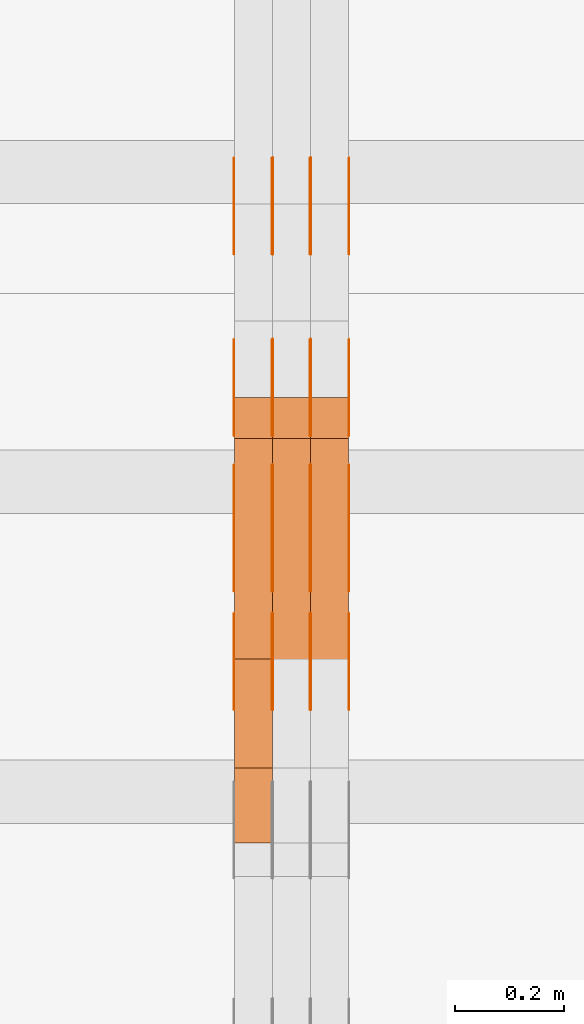
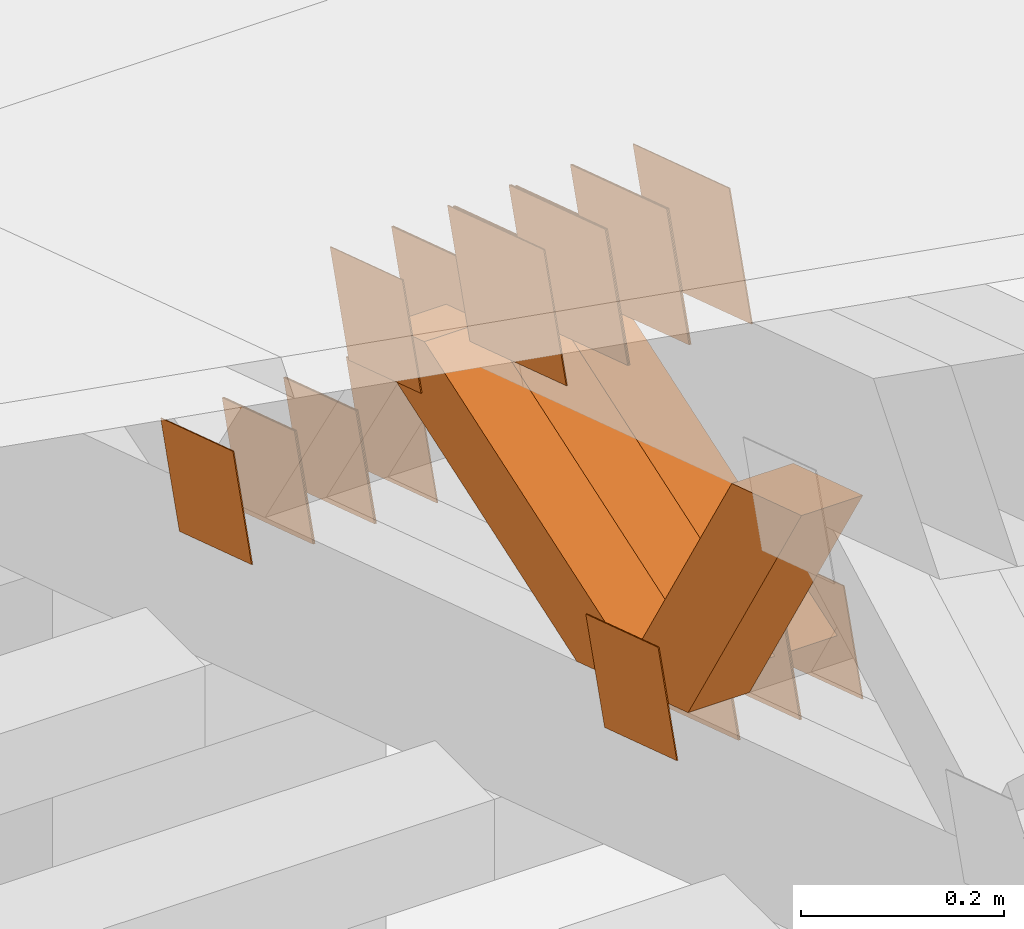
# One storey, part 224 of 385: 28 proxies.
"""IFC2X3 building model written with IfcOpenShell, lengths in millimetres."""

from ifc_helpers import new_model, entity, si_unit, converted_unit, derived_unit, direction, frame, origin, place, context, subcontext, project, spatial, polyline, outline, extrude, source, transform, mapped, material, type_object, type_shapes, element, save


model = new_model("IFC2X3")

# Units and contexts
model_context = context("Model", 3, precision=0.01, world=origin(), true_north=direction((6.12303176911189e-17, 1.0)))
body_context = subcontext(model_context, "Body", "Model", "MODEL_VIEW")
ifc_project = project(units=[si_unit("LENGTHUNIT", "METRE", prefix="MILLI"), si_unit("AREAUNIT", "SQUARE_METRE"), si_unit("VOLUMEUNIT", "CUBIC_METRE"), converted_unit("PLANEANGLEUNIT", "DEGREE", entity("IfcRatioMeasure", 0.0174532925199433), si_unit("PLANEANGLEUNIT", "RADIAN"), dimensions=[0, 0, 0, 0, 0, 0, 0]), si_unit("MASSUNIT", "GRAM", prefix="KILO"), derived_unit("MASSDENSITYUNIT", [(si_unit("MASSUNIT", "GRAM", prefix="KILO"), 1), (si_unit("LENGTHUNIT", "METRE"), -3)]), si_unit("TIMEUNIT", "SECOND"), si_unit("FREQUENCYUNIT", "HERTZ"), si_unit("THERMODYNAMICTEMPERATUREUNIT", "DEGREE_CELSIUS"), derived_unit("THERMALTRANSMITTANCEUNIT", [(si_unit("MASSUNIT", "GRAM", prefix="KILO"), 1), (si_unit("THERMODYNAMICTEMPERATUREUNIT", "KELVIN"), -1), (si_unit("TIMEUNIT", "SECOND"), -3)]), derived_unit("VOLUMETRICFLOWRATEUNIT", [(si_unit("LENGTHUNIT", "METRE"), 3), (si_unit("TIMEUNIT", "SECOND"), -1)]), si_unit("ELECTRICCURRENTUNIT", "AMPERE"), si_unit("ELECTRICVOLTAGEUNIT", "VOLT"), si_unit("POWERUNIT", "WATT"), si_unit("FORCEUNIT", "NEWTON", prefix="KILO"), si_unit("ILLUMINANCEUNIT", "LUX"), si_unit("LUMINOUSFLUXUNIT", "LUMEN"), si_unit("LUMINOUSINTENSITYUNIT", "CANDELA"), derived_unit("USERDEFINED", [(si_unit("MASSUNIT", "GRAM", prefix="KILO"), -1), (si_unit("LENGTHUNIT", "METRE"), -2), (si_unit("TIMEUNIT", "SECOND"), 3), (si_unit("LUMINOUSFLUXUNIT", "LUMEN"), 1)]), derived_unit("LINEARVELOCITYUNIT", [(si_unit("LENGTHUNIT", "METRE"), 1), (si_unit("TIMEUNIT", "SECOND"), -1)]), si_unit("PRESSUREUNIT", "PASCAL"), derived_unit("USERDEFINED", [(si_unit("LENGTHUNIT", "METRE"), -2), (si_unit("MASSUNIT", "GRAM", prefix="KILO"), 1), (si_unit("TIMEUNIT", "SECOND"), -2)])], contexts=[model_context])

# Site, building, storey
site_placement = place(None, origin())
site = spatial("IfcSite", under=ifc_project, at=site_placement, CompositionType="ELEMENT")
building_placement = place(site_placement, origin())
building = spatial("IfcBuilding", under=site, at=building_placement, CompositionType="ELEMENT")
storey_placement = place(building_placement, origin())
storey = spatial("IfcBuildingStorey", under=building, at=storey_placement, Name="Default", CompositionType="ELEMENT", Elevation=0.0)

# Proxies
ifc_material_1 = material(Name="IfcSurfaceStyle #315514")
building_element_proxy_type_1 = type_object("IfcBuildingElementProxyType", PredefinedType="NOTDEFINED", material=ifc_material_1)
shared_shape_1 = source(origin(), body_context, "Body", "SweptSolid", [
    extrude(outline(polyline([(-74.9998605591059, -59.9999264677526), (74.999875428623, -59.9999264677526), (74.9998605591068, 59.9999264677526), (-74.9998754286239, 59.9999264677526), (-74.9998605591059, -59.9999264677526)])), frame((75.0000889884782, 60.0000460315623, 0.0), z_axis=(0.0, 0.0, 1.0), x_axis=(-1.0, 0.0, 0.0)), (0.0, 0.0, 1.0), 1.3),
])
type_shapes(building_element_proxy_type_1, [shared_shape_1])
proxy_1_placement = place(building_placement, frame((24386.3, 20621.9679769682, 2241.76551219004), z_axis=(-1.0, 0.0, 0.0), x_axis=(0.0, -0.951056516295154, 0.309016994374948)))
element("IfcBuildingElementProxy", 1, at=proxy_1_placement, inside=storey, type_object=building_element_proxy_type_1, material=ifc_material_1, context=body_context, shape_type="MappedRepresentation", body=[
    mapped(shared_shape_1, transform((0.0, 0.0, 0.0), scale=1.0)),
])
ifc_material_2 = material(Name="IfcSurfaceStyle #315457")
building_element_proxy_type_2 = type_object("IfcBuildingElementProxyType", PredefinedType="NOTDEFINED", material=ifc_material_2)
shared_shape_2 = source(origin(), body_context, "Body", "SweptSolid", [
    extrude(outline(polyline([(-74.9998605591059, -59.9999264677526), (74.999875428623, -59.9999264677526), (74.9998605591068, 59.9999264677526), (-74.9998754286239, 59.9999264677526), (-74.9998605591059, -59.9999264677526)])), frame((75.0000889884782, 60.0000460315623, 0.0), z_axis=(0.0, 0.0, 1.0), x_axis=(-1.0, 0.0, 0.0)), (0.0, 0.0, 1.0), 1.3),
])
type_shapes(building_element_proxy_type_2, [shared_shape_2])
proxy_2_placement = place(building_placement, frame((24315.0, 20621.9679769682, 2241.76551219004), z_axis=(-1.0, 0.0, 0.0), x_axis=(0.0, -0.951056516295154, 0.309016994374948)))
element("IfcBuildingElementProxy", 2, at=proxy_2_placement, inside=storey, type_object=building_element_proxy_type_2, material=ifc_material_2, context=body_context, shape_type="MappedRepresentation", body=[
    mapped(shared_shape_2, transform((0.0, 0.0, 0.0), scale=1.0)),
])
ifc_material_3 = material(Name="IfcSurfaceStyle #315400")
building_element_proxy_type_3 = type_object("IfcBuildingElementProxyType", PredefinedType="NOTDEFINED", material=ifc_material_3)
shared_shape_3 = source(origin(), body_context, "Body", "SweptSolid", [
    extrude(outline(polyline([(-74.9998605591059, -59.9999264677526), (74.999875428623, -59.9999264677526), (74.9998605591068, 59.9999264677526), (-74.9998754286239, 59.9999264677526), (-74.9998605591059, -59.9999264677526)])), frame((75.0000889884782, 60.0000460315623, 0.0), z_axis=(0.0, 0.0, 1.0), x_axis=(-1.0, 0.0, 0.0)), (0.0, 0.0, 1.0), 1.3),
])
type_shapes(building_element_proxy_type_3, [shared_shape_3])
proxy_3_placement = place(building_placement, frame((24316.3, 20621.9679769682, 2241.76551219004), z_axis=(-1.0, 0.0, 0.0), x_axis=(0.0, -0.951056516295154, 0.309016994374948)))
element("IfcBuildingElementProxy", 3, at=proxy_3_placement, inside=storey, type_object=building_element_proxy_type_3, material=ifc_material_3, context=body_context, shape_type="MappedRepresentation", body=[
    mapped(shared_shape_3, transform((0.0, 0.0, 0.0), scale=1.0)),
])
ifc_material_4 = material(Name="IfcSurfaceStyle #315343")
building_element_proxy_type_4 = type_object("IfcBuildingElementProxyType", PredefinedType="NOTDEFINED", material=ifc_material_4)
shared_shape_4 = source(origin(), body_context, "Body", "SweptSolid", [
    extrude(outline(polyline([(-74.9998605591059, -59.9999264677526), (74.999875428623, -59.9999264677526), (74.9998605591068, 59.9999264677526), (-74.9998754286239, 59.9999264677526), (-74.9998605591059, -59.9999264677526)])), frame((75.0000889884782, 60.0000460315623, 0.0), z_axis=(0.0, 0.0, 1.0), x_axis=(-1.0, 0.0, 0.0)), (0.0, 0.0, 1.0), 1.29999999999999),
])
type_shapes(building_element_proxy_type_4, [shared_shape_4])
proxy_4_placement = place(building_placement, frame((24245.0, 20621.9679769682, 2241.76551219004), z_axis=(-1.0, 0.0, 0.0), x_axis=(0.0, -0.951056516295154, 0.309016994374948)))
element("IfcBuildingElementProxy", 4, at=proxy_4_placement, inside=storey, type_object=building_element_proxy_type_4, material=ifc_material_4, context=body_context, shape_type="MappedRepresentation", body=[
    mapped(shared_shape_4, transform((0.0, 0.0, 0.0), scale=1.0)),
])
ifc_material_5 = material(Name="IfcSurfaceStyle #315286")
building_element_proxy_type_5 = type_object("IfcBuildingElementProxyType", PredefinedType="NOTDEFINED", material=ifc_material_5)
shared_shape_5 = source(origin(), body_context, "Body", "SweptSolid", [
    extrude(outline(polyline([(-74.9998605591059, -59.9999264677526), (74.999875428623, -59.9999264677526), (74.9998605591068, 59.9999264677526), (-74.9998754286239, 59.9999264677526), (-74.9998605591059, -59.9999264677526)])), frame((75.0000889884782, 60.0000460315623, 0.0), z_axis=(0.0, 0.0, 1.0), x_axis=(-1.0, 0.0, 0.0)), (0.0, 0.0, 1.0), 1.29999999999999),
])
type_shapes(building_element_proxy_type_5, [shared_shape_5])
proxy_5_placement = place(building_placement, frame((24246.3, 20621.9679769682, 2241.76551219004), z_axis=(-1.0, 0.0, 0.0), x_axis=(0.0, -0.951056516295154, 0.309016994374948)))
element("IfcBuildingElementProxy", 5, at=proxy_5_placement, inside=storey, type_object=building_element_proxy_type_5, material=ifc_material_5, context=body_context, shape_type="MappedRepresentation", body=[
    mapped(shared_shape_5, transform((0.0, 0.0, 0.0), scale=1.0)),
])
ifc_material_6 = material(Name="IfcSurfaceStyle #315229")
building_element_proxy_type_6 = type_object("IfcBuildingElementProxyType", PredefinedType="NOTDEFINED", material=ifc_material_6)
shared_shape_6 = source(origin(), body_context, "Body", "SweptSolid", [
    extrude(outline(polyline([(-74.9998605591059, -59.9999264677526), (74.999875428623, -59.9999264677526), (74.9998605591068, 59.9999264677526), (-74.9998754286239, 59.9999264677526), (-74.9998605591059, -59.9999264677526)])), frame((75.0000889884782, 60.0000460315623, 0.0), z_axis=(0.0, 0.0, 1.0), x_axis=(-1.0, 0.0, 0.0)), (0.0, 0.0, 1.0), 1.29999999999999),
])
type_shapes(building_element_proxy_type_6, [shared_shape_6])
proxy_6_placement = place(building_placement, frame((24175.0, 20621.9679769682, 2241.76551219004), z_axis=(-1.0, 0.0, 0.0), x_axis=(0.0, -0.951056516295154, 0.309016994374948)))
element("IfcBuildingElementProxy", 6, at=proxy_6_placement, inside=storey, type_object=building_element_proxy_type_6, material=ifc_material_6, context=body_context, shape_type="MappedRepresentation", body=[
    mapped(shared_shape_6, transform((0.0, 0.0, 0.0), scale=1.0)),
])
ifc_material_7 = material(Name="IfcSurfaceStyle #313804")
building_element_proxy_type_7 = type_object("IfcBuildingElementProxyType", PredefinedType="NOTDEFINED", material=ifc_material_7)
shared_shape_7 = source(origin(), body_context, "Body", "SweptSolid", [
    extrude(outline(polyline([(-100.000260677523, -72.0000050220369), (100.000341220114, -72.0000050220369), (99.9997962944585, 72.0000050220369), (-99.9998768370492, 72.0000050220369), (-100.000260677523, -72.0000050220369)])), frame((100.000341220114, 72.0001826453454, 0.0), z_axis=(0.0, 0.0, 1.0), x_axis=(-1.0, 0.0, 0.0)), (0.0, 0.0, 1.0), 1.3),
])
type_shapes(building_element_proxy_type_7, [shared_shape_7])
proxy_7_placement = place(building_placement, frame((24386.3, 20382.8706354426, 2409.35285895246), z_axis=(-1.0, 0.0, 0.0), x_axis=(0.0, -0.951056516295154, 0.309016994374948)))
element("IfcBuildingElementProxy", 7, at=proxy_7_placement, inside=storey, type_object=building_element_proxy_type_7, material=ifc_material_7, context=body_context, shape_type="MappedRepresentation", body=[
    mapped(shared_shape_7, transform((0.0, 0.0, 0.0), scale=1.0)),
])
ifc_material_8 = material(Name="IfcSurfaceStyle #313747")
building_element_proxy_type_8 = type_object("IfcBuildingElementProxyType", PredefinedType="NOTDEFINED", material=ifc_material_8)
shared_shape_8 = source(origin(), body_context, "Body", "SweptSolid", [
    extrude(outline(polyline([(-100.000260677523, -72.0000050220369), (100.000341220114, -72.0000050220369), (99.9997962944585, 72.0000050220369), (-99.9998768370492, 72.0000050220369), (-100.000260677523, -72.0000050220369)])), frame((100.000341220114, 72.0001826453454, 0.0), z_axis=(0.0, 0.0, 1.0), x_axis=(-1.0, 0.0, 0.0)), (0.0, 0.0, 1.0), 1.3),
])
type_shapes(building_element_proxy_type_8, [shared_shape_8])
proxy_8_placement = place(building_placement, frame((24315.0, 20382.8706354426, 2409.35285895246), z_axis=(-1.0, 0.0, 0.0), x_axis=(0.0, -0.951056516295154, 0.309016994374948)))
element("IfcBuildingElementProxy", 8, at=proxy_8_placement, inside=storey, type_object=building_element_proxy_type_8, material=ifc_material_8, context=body_context, shape_type="MappedRepresentation", body=[
    mapped(shared_shape_8, transform((0.0, 0.0, 0.0), scale=1.0)),
])
ifc_material_9 = material(Name="IfcSurfaceStyle #313690")
building_element_proxy_type_9 = type_object("IfcBuildingElementProxyType", PredefinedType="NOTDEFINED", material=ifc_material_9)
shared_shape_9 = source(origin(), body_context, "Body", "SweptSolid", [
    extrude(outline(polyline([(-100.000260677523, -72.0000050220369), (100.000341220114, -72.0000050220369), (99.9997962944585, 72.0000050220369), (-99.9998768370492, 72.0000050220369), (-100.000260677523, -72.0000050220369)])), frame((100.000341220114, 72.0001826453454, 0.0), z_axis=(0.0, 0.0, 1.0), x_axis=(-1.0, 0.0, 0.0)), (0.0, 0.0, 1.0), 1.3),
])
type_shapes(building_element_proxy_type_9, [shared_shape_9])
proxy_9_placement = place(building_placement, frame((24316.3, 20382.8706354426, 2409.35285895246), z_axis=(-1.0, 0.0, 0.0), x_axis=(0.0, -0.951056516295154, 0.309016994374948)))
element("IfcBuildingElementProxy", 9, at=proxy_9_placement, inside=storey, type_object=building_element_proxy_type_9, material=ifc_material_9, context=body_context, shape_type="MappedRepresentation", body=[
    mapped(shared_shape_9, transform((0.0, 0.0, 0.0), scale=1.0)),
])
ifc_material_10 = material(Name="IfcSurfaceStyle #313633")
building_element_proxy_type_10 = type_object("IfcBuildingElementProxyType", PredefinedType="NOTDEFINED", material=ifc_material_10)
shared_shape_10 = source(origin(), body_context, "Body", "SweptSolid", [
    extrude(outline(polyline([(-100.000260677523, -72.0000050220369), (100.000341220114, -72.0000050220369), (99.9997962944585, 72.0000050220369), (-99.9998768370492, 72.0000050220369), (-100.000260677523, -72.0000050220369)])), frame((100.000341220114, 72.0001826453454, 0.0), z_axis=(0.0, 0.0, 1.0), x_axis=(-1.0, 0.0, 0.0)), (0.0, 0.0, 1.0), 1.29999999999998),
])
type_shapes(building_element_proxy_type_10, [shared_shape_10])
proxy_10_placement = place(building_placement, frame((24245.0, 20382.8706354426, 2409.35285895246), z_axis=(-1.0, 0.0, 0.0), x_axis=(0.0, -0.951056516295154, 0.309016994374948)))
element("IfcBuildingElementProxy", 10, at=proxy_10_placement, inside=storey, type_object=building_element_proxy_type_10, material=ifc_material_10, context=body_context, shape_type="MappedRepresentation", body=[
    mapped(shared_shape_10, transform((0.0, 0.0, 0.0), scale=1.0)),
])
ifc_material_11 = material(Name="IfcSurfaceStyle #313576")
building_element_proxy_type_11 = type_object("IfcBuildingElementProxyType", PredefinedType="NOTDEFINED", material=ifc_material_11)
shared_shape_11 = source(origin(), body_context, "Body", "SweptSolid", [
    extrude(outline(polyline([(-100.000260677523, -72.0000050220369), (100.000341220114, -72.0000050220369), (99.9997962944585, 72.0000050220369), (-99.9998768370492, 72.0000050220369), (-100.000260677523, -72.0000050220369)])), frame((100.000341220114, 72.0001826453454, 0.0), z_axis=(0.0, 0.0, 1.0), x_axis=(-1.0, 0.0, 0.0)), (0.0, 0.0, 1.0), 1.29999999999998),
])
type_shapes(building_element_proxy_type_11, [shared_shape_11])
proxy_11_placement = place(building_placement, frame((24246.3, 20382.8706354426, 2409.35285895246), z_axis=(-1.0, 0.0, 0.0), x_axis=(0.0, -0.951056516295154, 0.309016994374948)))
element("IfcBuildingElementProxy", 11, at=proxy_11_placement, inside=storey, type_object=building_element_proxy_type_11, material=ifc_material_11, context=body_context, shape_type="MappedRepresentation", body=[
    mapped(shared_shape_11, transform((0.0, 0.0, 0.0), scale=1.0)),
])
ifc_material_12 = material(Name="IfcSurfaceStyle #313519")
building_element_proxy_type_12 = type_object("IfcBuildingElementProxyType", PredefinedType="NOTDEFINED", material=ifc_material_12)
shared_shape_12 = source(origin(), body_context, "Body", "SweptSolid", [
    extrude(outline(polyline([(-100.000260677523, -72.0000050220369), (100.000341220114, -72.0000050220369), (99.9997962944585, 72.0000050220369), (-99.9998768370492, 72.0000050220369), (-100.000260677523, -72.0000050220369)])), frame((100.000341220114, 72.0001826453454, 0.0), z_axis=(0.0, 0.0, 1.0), x_axis=(-1.0, 0.0, 0.0)), (0.0, 0.0, 1.0), 1.29999999999999),
])
type_shapes(building_element_proxy_type_12, [shared_shape_12])
proxy_12_placement = place(building_placement, frame((24175.0, 20382.8706354426, 2409.35285895246), z_axis=(-1.0, 0.0, 0.0), x_axis=(0.0, -0.951056516295154, 0.309016994374948)))
element("IfcBuildingElementProxy", 12, at=proxy_12_placement, inside=storey, type_object=building_element_proxy_type_12, material=ifc_material_12, context=body_context, shape_type="MappedRepresentation", body=[
    mapped(shared_shape_12, transform((0.0, 0.0, 0.0), scale=1.0)),
])
ifc_material_13 = material(Name="IfcSurfaceStyle #307306")
building_element_proxy_type_13 = type_object("IfcBuildingElementProxyType", PredefinedType="NOTDEFINED", material=ifc_material_13)
shared_shape_13 = source(origin(), body_context, "Body", "SweptSolid", [
    extrude(outline(polyline([(-74.9998605591118, -59.9999264677598), (74.9998754286171, -59.9999264677598), (74.9998605591136, 59.9999264677598), (-74.9998754286189, 59.9999264677598), (-74.9998605591118, -59.9999264677598)])), frame((75.0000347664736, 60.0000016373434, 0.0), z_axis=(0.0, 0.0, 1.0), x_axis=(-1.0, 0.0, 0.0)), (0.0, 0.0, 1.0), 1.3),
])
type_shapes(building_element_proxy_type_13, [shared_shape_13])
proxy_13_placement = place(building_placement, frame((24386.3, 20117.0890328685, 2105.40814929196), z_axis=(-1.0, 0.0, 0.0), x_axis=(0.0, -0.951056516295124, 0.309016994375039)))
element("IfcBuildingElementProxy", 13, at=proxy_13_placement, inside=storey, type_object=building_element_proxy_type_13, material=ifc_material_13, context=body_context, shape_type="MappedRepresentation", body=[
    mapped(shared_shape_13, transform((0.0, 0.0, 0.0), scale=1.0)),
])
ifc_material_14 = material(Name="IfcSurfaceStyle #307249")
building_element_proxy_type_14 = type_object("IfcBuildingElementProxyType", PredefinedType="NOTDEFINED", material=ifc_material_14)
shared_shape_14 = source(origin(), body_context, "Body", "SweptSolid", [
    extrude(outline(polyline([(-74.9998605591118, -59.9999264677598), (74.9998754286171, -59.9999264677598), (74.9998605591136, 59.9999264677598), (-74.9998754286189, 59.9999264677598), (-74.9998605591118, -59.9999264677598)])), frame((75.0000347664736, 60.0000016373434, 0.0), z_axis=(0.0, 0.0, 1.0), x_axis=(-1.0, 0.0, 0.0)), (0.0, 0.0, 1.0), 1.3),
])
type_shapes(building_element_proxy_type_14, [shared_shape_14])
proxy_14_placement = place(building_placement, frame((24315.0, 20117.0890328685, 2105.40814929196), z_axis=(-1.0, 0.0, 0.0), x_axis=(0.0, -0.951056516295124, 0.309016994375039)))
element("IfcBuildingElementProxy", 14, at=proxy_14_placement, inside=storey, type_object=building_element_proxy_type_14, material=ifc_material_14, context=body_context, shape_type="MappedRepresentation", body=[
    mapped(shared_shape_14, transform((0.0, 0.0, 0.0), scale=1.0)),
])
ifc_material_15 = material(Name="IfcSurfaceStyle #307192")
building_element_proxy_type_15 = type_object("IfcBuildingElementProxyType", PredefinedType="NOTDEFINED", material=ifc_material_15)
shared_shape_15 = source(origin(), body_context, "Body", "SweptSolid", [
    extrude(outline(polyline([(-74.9998605591118, -59.9999264677598), (74.9998754286171, -59.9999264677598), (74.9998605591136, 59.9999264677598), (-74.9998754286189, 59.9999264677598), (-74.9998605591118, -59.9999264677598)])), frame((75.0000347664736, 60.0000016373434, 0.0), z_axis=(0.0, 0.0, 1.0), x_axis=(-1.0, 0.0, 0.0)), (0.0, 0.0, 1.0), 1.3),
])
type_shapes(building_element_proxy_type_15, [shared_shape_15])
proxy_15_placement = place(building_placement, frame((24316.3, 20117.0890328685, 2105.40814929196), z_axis=(-1.0, 0.0, 0.0), x_axis=(0.0, -0.951056516295124, 0.309016994375039)))
element("IfcBuildingElementProxy", 15, at=proxy_15_placement, inside=storey, type_object=building_element_proxy_type_15, material=ifc_material_15, context=body_context, shape_type="MappedRepresentation", body=[
    mapped(shared_shape_15, transform((0.0, 0.0, 0.0), scale=1.0)),
])
ifc_material_16 = material(Name="IfcSurfaceStyle #307135")
building_element_proxy_type_16 = type_object("IfcBuildingElementProxyType", PredefinedType="NOTDEFINED", material=ifc_material_16)
shared_shape_16 = source(origin(), body_context, "Body", "SweptSolid", [
    extrude(outline(polyline([(-74.9998605591118, -59.9999264677598), (74.9998754286171, -59.9999264677598), (74.9998605591136, 59.9999264677598), (-74.9998754286189, 59.9999264677598), (-74.9998605591118, -59.9999264677598)])), frame((75.0000347664736, 60.0000016373434, 0.0), z_axis=(0.0, 0.0, 1.0), x_axis=(-1.0, 0.0, 0.0)), (0.0, 0.0, 1.0), 1.29999999999999),
])
type_shapes(building_element_proxy_type_16, [shared_shape_16])
proxy_16_placement = place(building_placement, frame((24245.0, 20117.0890328685, 2105.40814929196), z_axis=(-1.0, 0.0, 0.0), x_axis=(0.0, -0.951056516295124, 0.309016994375039)))
element("IfcBuildingElementProxy", 16, at=proxy_16_placement, inside=storey, type_object=building_element_proxy_type_16, material=ifc_material_16, context=body_context, shape_type="MappedRepresentation", body=[
    mapped(shared_shape_16, transform((0.0, 0.0, 0.0), scale=1.0)),
])
ifc_material_17 = material(Name="IfcSurfaceStyle #307078")
building_element_proxy_type_17 = type_object("IfcBuildingElementProxyType", PredefinedType="NOTDEFINED", material=ifc_material_17)
shared_shape_17 = source(origin(), body_context, "Body", "SweptSolid", [
    extrude(outline(polyline([(-74.9998605591118, -59.9999264677598), (74.9998754286171, -59.9999264677598), (74.9998605591136, 59.9999264677598), (-74.9998754286189, 59.9999264677598), (-74.9998605591118, -59.9999264677598)])), frame((75.0000347664736, 60.0000016373434, 0.0), z_axis=(0.0, 0.0, 1.0), x_axis=(-1.0, 0.0, 0.0)), (0.0, 0.0, 1.0), 1.29999999999999),
])
type_shapes(building_element_proxy_type_17, [shared_shape_17])
proxy_17_placement = place(building_placement, frame((24246.3, 20117.0890328685, 2105.40814929196), z_axis=(-1.0, 0.0, 0.0), x_axis=(0.0, -0.951056516295124, 0.309016994375039)))
element("IfcBuildingElementProxy", 17, at=proxy_17_placement, inside=storey, type_object=building_element_proxy_type_17, material=ifc_material_17, context=body_context, shape_type="MappedRepresentation", body=[
    mapped(shared_shape_17, transform((0.0, 0.0, 0.0), scale=1.0)),
])
ifc_material_18 = material(Name="IfcSurfaceStyle #307021")
building_element_proxy_type_18 = type_object("IfcBuildingElementProxyType", PredefinedType="NOTDEFINED", material=ifc_material_18)
shared_shape_18 = source(origin(), body_context, "Body", "SweptSolid", [
    extrude(outline(polyline([(-74.9998605591118, -59.9999264677598), (74.9998754286171, -59.9999264677598), (74.9998605591136, 59.9999264677598), (-74.9998754286189, 59.9999264677598), (-74.9998605591118, -59.9999264677598)])), frame((75.0000347664736, 60.0000016373434, 0.0), z_axis=(0.0, 0.0, 1.0), x_axis=(-1.0, 0.0, 0.0)), (0.0, 0.0, 1.0), 1.29999999999999),
])
type_shapes(building_element_proxy_type_18, [shared_shape_18])
proxy_18_placement = place(building_placement, frame((24175.0, 20117.0890328685, 2105.40814929196), z_axis=(-1.0, 0.0, 0.0), x_axis=(0.0, -0.951056516295124, 0.309016994375039)))
element("IfcBuildingElementProxy", 18, at=proxy_18_placement, inside=storey, type_object=building_element_proxy_type_18, material=ifc_material_18, context=body_context, shape_type="MappedRepresentation", body=[
    mapped(shared_shape_18, transform((0.0, 0.0, 0.0), scale=1.0)),
])
ifc_material_19 = material(Name="IfcSurfaceStyle #306964")
building_element_proxy_type_19 = type_object("IfcBuildingElementProxyType", PredefinedType="NOTDEFINED", material=ifc_material_19)
shared_shape_19 = source(origin(), body_context, "Body", "SweptSolid", [
    extrude(outline(polyline([(-74.9998794200132, -59.999984515643), (74.9998565677174, -59.999984515643), (74.9998794200123, 59.999984515643), (-74.9998565677165, 59.999984515643), (-74.9998794200132, -59.999984515643)])), frame((75.0002235343086, 60.0000596852268, 0.0), z_axis=(0.0, 0.0, 1.0), x_axis=(-1.0, 0.0, 0.0)), (0.0, 0.0, 1.0), 1.3),
])
type_shapes(building_element_proxy_type_19, [shared_shape_19])
proxy_19_placement = place(building_placement, frame((24386.3, 20956.2317725846, 1832.75404405346), z_axis=(-1.0, 0.0, 0.0), x_axis=(0.0, -0.951056516295124, 0.309016994375039)))
element("IfcBuildingElementProxy", 19, at=proxy_19_placement, inside=storey, type_object=building_element_proxy_type_19, material=ifc_material_19, context=body_context, shape_type="MappedRepresentation", body=[
    mapped(shared_shape_19, transform((0.0, 0.0, 0.0), scale=1.0)),
])
ifc_material_20 = material(Name="IfcSurfaceStyle #306907")
building_element_proxy_type_20 = type_object("IfcBuildingElementProxyType", PredefinedType="NOTDEFINED", material=ifc_material_20)
shared_shape_20 = source(origin(), body_context, "Body", "SweptSolid", [
    extrude(outline(polyline([(-74.9998794200132, -59.999984515643), (74.9998565677174, -59.999984515643), (74.9998794200123, 59.999984515643), (-74.9998565677165, 59.999984515643), (-74.9998794200132, -59.999984515643)])), frame((75.0002235343086, 60.0000596852268, 0.0), z_axis=(0.0, 0.0, 1.0), x_axis=(-1.0, 0.0, 0.0)), (0.0, 0.0, 1.0), 1.3),
])
type_shapes(building_element_proxy_type_20, [shared_shape_20])
proxy_20_placement = place(building_placement, frame((24315.0, 20956.2317725846, 1832.75404405346), z_axis=(-1.0, 0.0, 0.0), x_axis=(0.0, -0.951056516295124, 0.309016994375039)))
element("IfcBuildingElementProxy", 20, at=proxy_20_placement, inside=storey, type_object=building_element_proxy_type_20, material=ifc_material_20, context=body_context, shape_type="MappedRepresentation", body=[
    mapped(shared_shape_20, transform((0.0, 0.0, 0.0), scale=1.0)),
])
ifc_material_21 = material(Name="IfcSurfaceStyle #306850")
building_element_proxy_type_21 = type_object("IfcBuildingElementProxyType", PredefinedType="NOTDEFINED", material=ifc_material_21)
shared_shape_21 = source(origin(), body_context, "Body", "SweptSolid", [
    extrude(outline(polyline([(-74.9998794200132, -59.999984515643), (74.9998565677174, -59.999984515643), (74.9998794200123, 59.999984515643), (-74.9998565677165, 59.999984515643), (-74.9998794200132, -59.999984515643)])), frame((75.0002235343086, 60.0000596852268, 0.0), z_axis=(0.0, 0.0, 1.0), x_axis=(-1.0, 0.0, 0.0)), (0.0, 0.0, 1.0), 1.3),
])
type_shapes(building_element_proxy_type_21, [shared_shape_21])
proxy_21_placement = place(building_placement, frame((24316.3, 20956.2317725846, 1832.75404405346), z_axis=(-1.0, 0.0, 0.0), x_axis=(0.0, -0.951056516295124, 0.309016994375039)))
element("IfcBuildingElementProxy", 21, at=proxy_21_placement, inside=storey, type_object=building_element_proxy_type_21, material=ifc_material_21, context=body_context, shape_type="MappedRepresentation", body=[
    mapped(shared_shape_21, transform((0.0, 0.0, 0.0), scale=1.0)),
])
ifc_material_22 = material(Name="IfcSurfaceStyle #306793")
building_element_proxy_type_22 = type_object("IfcBuildingElementProxyType", PredefinedType="NOTDEFINED", material=ifc_material_22)
shared_shape_22 = source(origin(), body_context, "Body", "SweptSolid", [
    extrude(outline(polyline([(-74.9998794200132, -59.999984515643), (74.9998565677174, -59.999984515643), (74.9998794200123, 59.999984515643), (-74.9998565677165, 59.999984515643), (-74.9998794200132, -59.999984515643)])), frame((75.0002235343086, 60.0000596852268, 0.0), z_axis=(0.0, 0.0, 1.0), x_axis=(-1.0, 0.0, 0.0)), (0.0, 0.0, 1.0), 1.29999999999999),
])
type_shapes(building_element_proxy_type_22, [shared_shape_22])
proxy_22_placement = place(building_placement, frame((24245.0, 20956.2317725846, 1832.75404405346), z_axis=(-1.0, 0.0, 0.0), x_axis=(0.0, -0.951056516295124, 0.309016994375039)))
element("IfcBuildingElementProxy", 22, at=proxy_22_placement, inside=storey, type_object=building_element_proxy_type_22, material=ifc_material_22, context=body_context, shape_type="MappedRepresentation", body=[
    mapped(shared_shape_22, transform((0.0, 0.0, 0.0), scale=1.0)),
])
ifc_material_23 = material(Name="IfcSurfaceStyle #306736")
building_element_proxy_type_23 = type_object("IfcBuildingElementProxyType", PredefinedType="NOTDEFINED", material=ifc_material_23)
shared_shape_23 = source(origin(), body_context, "Body", "SweptSolid", [
    extrude(outline(polyline([(-74.9998794200132, -59.999984515643), (74.9998565677174, -59.999984515643), (74.9998794200123, 59.999984515643), (-74.9998565677165, 59.999984515643), (-74.9998794200132, -59.999984515643)])), frame((75.0002235343086, 60.0000596852268, 0.0), z_axis=(0.0, 0.0, 1.0), x_axis=(-1.0, 0.0, 0.0)), (0.0, 0.0, 1.0), 1.29999999999999),
])
type_shapes(building_element_proxy_type_23, [shared_shape_23])
proxy_23_placement = place(building_placement, frame((24246.3, 20956.2317725846, 1832.75404405346), z_axis=(-1.0, 0.0, 0.0), x_axis=(0.0, -0.951056516295124, 0.309016994375039)))
element("IfcBuildingElementProxy", 23, at=proxy_23_placement, inside=storey, type_object=building_element_proxy_type_23, material=ifc_material_23, context=body_context, shape_type="MappedRepresentation", body=[
    mapped(shared_shape_23, transform((0.0, 0.0, 0.0), scale=1.0)),
])
ifc_material_24 = material(Name="IfcSurfaceStyle #306679")
building_element_proxy_type_24 = type_object("IfcBuildingElementProxyType", PredefinedType="NOTDEFINED", material=ifc_material_24)
shared_shape_24 = source(origin(), body_context, "Body", "SweptSolid", [
    extrude(outline(polyline([(-74.9998794200132, -59.999984515643), (74.9998565677174, -59.999984515643), (74.9998794200123, 59.999984515643), (-74.9998565677165, 59.999984515643), (-74.9998794200132, -59.999984515643)])), frame((75.0002235343086, 60.0000596852268, 0.0), z_axis=(0.0, 0.0, 1.0), x_axis=(-1.0, 0.0, 0.0)), (0.0, 0.0, 1.0), 1.29999999999999),
])
type_shapes(building_element_proxy_type_24, [shared_shape_24])
proxy_24_placement = place(building_placement, frame((24175.0, 20956.2317725846, 1832.75404405346), z_axis=(-1.0, 0.0, 0.0), x_axis=(0.0, -0.951056516295124, 0.309016994375039)))
element("IfcBuildingElementProxy", 24, at=proxy_24_placement, inside=storey, type_object=building_element_proxy_type_24, material=ifc_material_24, context=body_context, shape_type="MappedRepresentation", body=[
    mapped(shared_shape_24, transform((0.0, 0.0, 0.0), scale=1.0)),
])
ifc_material_25 = material(Name="IfcSurfaceStyle #289966")
building_element_proxy_type_25 = type_object("IfcBuildingElementProxyType", Name="T1-W34 289964", PredefinedType="NOTDEFINED", material=ifc_material_25)
shared_shape_25 = source(origin(), body_context, "Body", "SweptSolid", [
    extrude(outline(polyline([(-197.657161937088, -47.499796538607), (193.17680883218, -47.499796538607), (182.92464491562, -1.98968224184526e-05), (128.354123102956, 47.4998064870182), (-306.798414913668, 47.4998064870182), (-197.657161937088, -47.499796538607)])), frame((193.176852028916, 47.4998566383869, 0.0), z_axis=(0.0, 0.0, 1.0), x_axis=(-1.0, 0.0, 0.0)), (0.0, 0.0, 1.0), 70.0),
])
type_shapes(building_element_proxy_type_25, [shared_shape_25])
proxy_25_placement = place(building_placement, frame((24245.0, 19987.8030409043, 2165.75390635484), z_axis=(-1.0, 0.0, 0.0), x_axis=(0.0, -0.514479403471631, 0.857502736674044)))
element("IfcBuildingElementProxy", 25, at=proxy_25_placement, inside=storey, type_object=building_element_proxy_type_25, material=ifc_material_25, Name="T1-W34", context=body_context, shape_type="MappedRepresentation", body=[
    mapped(shared_shape_25, transform((0.0, 0.0, 0.0), scale=1.0)),
])
ifc_material_26 = material(Name="IfcSurfaceStyle #289702")
building_element_proxy_type_26 = type_object("IfcBuildingElementProxyType", Name="T1-W26 289700", PredefinedType="NOTDEFINED", material=ifc_material_26)
shared_shape_26 = source(origin(), body_context, "Body", "SweptSolid", [
    extrude(outline(polyline([(-339.390941716546, -47.5001331548025), (137.738864791781, -47.5001331548025), (201.272298560955, 6.02772073885038e-05), (212.703852542003, 47.5001030161988), (-212.324074178193, 47.5001030161988), (-339.390941716546, -47.5001331548025)])), frame((212.703852542003, 47.5001030161988, 0.0), z_axis=(0.0, 0.0, 1.0), x_axis=(-1.0, 0.0, 0.0)), (0.0, 0.0, 1.0), 70.0),
])
type_shapes(building_element_proxy_type_26, [shared_shape_26])
proxy_26_placement = place(building_placement, frame((24385.0, 20576.541015625, 2286.80981445313), z_axis=(-1.0, 0.0, 0.0), x_axis=(0.0, -0.946743816465327, -0.321987804093053)))
element("IfcBuildingElementProxy", 26, at=proxy_26_placement, inside=storey, type_object=building_element_proxy_type_26, material=ifc_material_26, Name="T1-W26", context=body_context, shape_type="MappedRepresentation", body=[
    mapped(shared_shape_26, transform((0.0, 0.0, 0.0), scale=1.0)),
])
ifc_material_27 = material(Name="IfcSurfaceStyle #289636")
building_element_proxy_type_27 = type_object("IfcBuildingElementProxyType", Name="T1-W26 289634", PredefinedType="NOTDEFINED", material=ifc_material_27)
shared_shape_27 = source(origin(), body_context, "Body", "SweptSolid", [
    extrude(outline(polyline([(-339.390941716546, -47.5001331548025), (137.738864791781, -47.5001331548025), (201.272298560955, 6.02772073885038e-05), (212.703852542003, 47.5001030161988), (-212.324074178193, 47.5001030161988), (-339.390941716546, -47.5001331548025)])), frame((212.703852542003, 47.5001030161988, 0.0), z_axis=(0.0, 0.0, 1.0), x_axis=(-1.0, 0.0, 0.0)), (0.0, 0.0, 1.0), 70.0),
])
type_shapes(building_element_proxy_type_27, [shared_shape_27])
proxy_27_placement = place(building_placement, frame((24315.0, 20576.541015625, 2286.80981445313), z_axis=(-1.0, 0.0, 0.0), x_axis=(0.0, -0.946743816465327, -0.321987804093053)))
element("IfcBuildingElementProxy", 27, at=proxy_27_placement, inside=storey, type_object=building_element_proxy_type_27, material=ifc_material_27, Name="T1-W26", context=body_context, shape_type="MappedRepresentation", body=[
    mapped(shared_shape_27, transform((0.0, 0.0, 0.0), scale=1.0)),
])
ifc_material_28 = material(Name="IfcSurfaceStyle #289570")
building_element_proxy_type_28 = type_object("IfcBuildingElementProxyType", Name="T1-W26 289568", PredefinedType="NOTDEFINED", material=ifc_material_28)
shared_shape_28 = source(origin(), body_context, "Body", "SweptSolid", [
    extrude(outline(polyline([(-339.390941716546, -47.5001331548025), (137.738864791781, -47.5001331548025), (201.272298560955, 6.02772073885038e-05), (212.703852542003, 47.5001030161988), (-212.324074178193, 47.5001030161988), (-339.390941716546, -47.5001331548025)])), frame((212.703852542003, 47.5001030161988, 0.0), z_axis=(0.0, 0.0, 1.0), x_axis=(-1.0, 0.0, 0.0)), (0.0, 0.0, 1.0), 70.0),
])
type_shapes(building_element_proxy_type_28, [shared_shape_28])
proxy_28_placement = place(building_placement, frame((24245.0, 20576.541015625, 2286.80981445313), z_axis=(-1.0, 0.0, 0.0), x_axis=(0.0, -0.946743816465327, -0.321987804093053)))
element("IfcBuildingElementProxy", 28, at=proxy_28_placement, inside=storey, type_object=building_element_proxy_type_28, material=ifc_material_28, Name="T1-W26", context=body_context, shape_type="MappedRepresentation", body=[
    mapped(shared_shape_28, transform((0.0, 0.0, 0.0), scale=1.0)),
])

save(model, "model.ifc")
